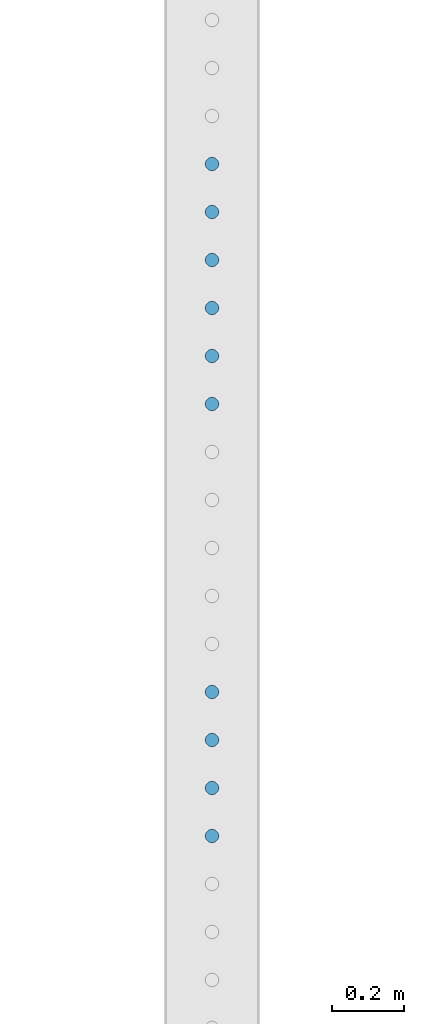
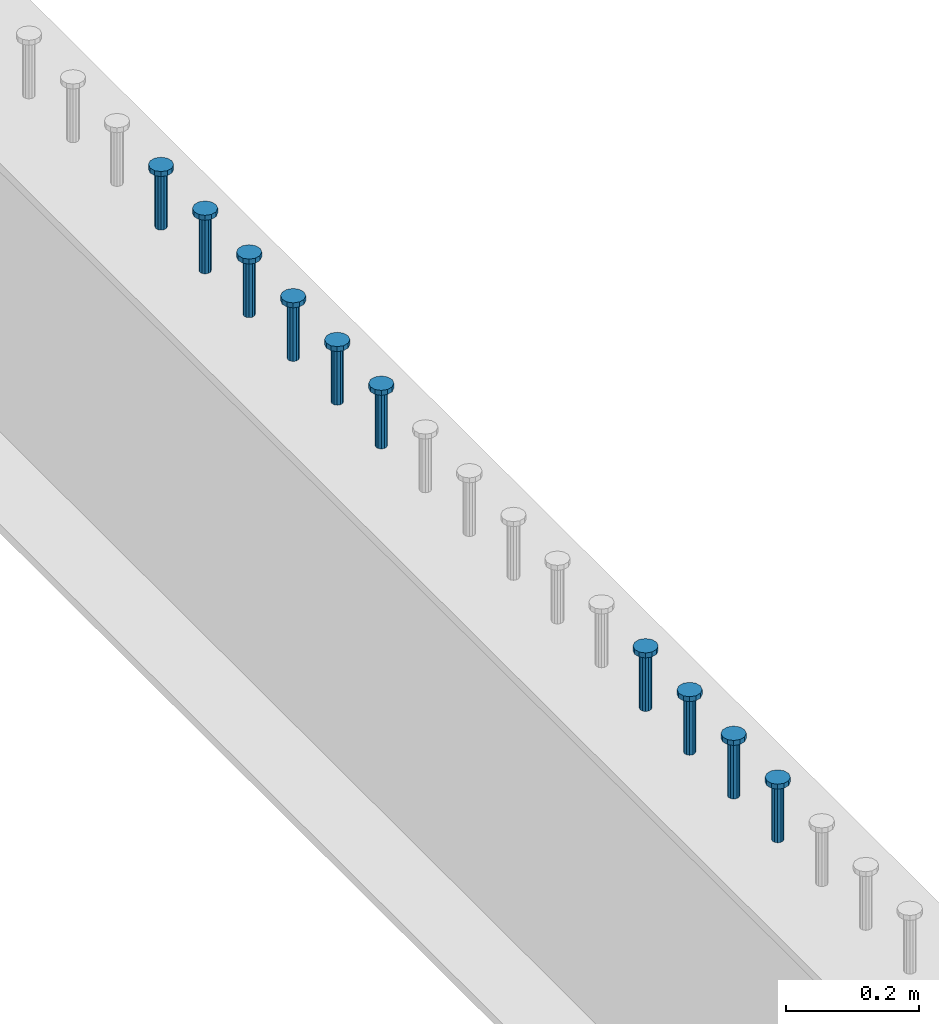
# One storey, part 947 of 1763: 10 columns, 10 elements without a shape of their own.
"""IFC2X3 building model written with IfcOpenShell, lengths in millimetres."""

import ifcopenshell
import ifcopenshell.guid

model = None  # the IFC model being written
_history = None  # IfcOwnerHistory: only IFC2X3 demands one
_inside = {}  # id of a spatial element -> (the spatial element, [elements in it])
_under = {}  # id of a project, library or spatial element -> (it, [spatial elements below it])
_declared = {}  # id of a project -> (the project, [libraries it declares])
_typed = {}  # id of a type object -> (the type object, [elements of that type])
_made_of = {}  # id of a material, layer set ... -> (it, [elements and type objects made of it])


def new_model(schema):
    """Start an empty IFC model of exactly this schema.

    Asked for "IFC4X3", IfcOpenShell would pick the latest addendum, in which some entities
    have other attributes; the version numbers below select the first issue.
    IFC2X3 requires an IfcOwnerHistory on every rooted entity: one is made here for all.
    """
    global model, _history
    if schema == "IFC4X3":
        model = ifcopenshell.file(schema_version=(4, 3, 0, 0))
    else:
        model = ifcopenshell.file(schema=schema)
    _inside.clear()
    _under.clear()
    _declared.clear()
    _typed.clear()
    _made_of.clear()
    _history = None
    if model.schema == "IFC2X3":
        org = make("IfcOrganization", Name="unknown")
        user = make(
            "IfcPersonAndOrganization",
            ThePerson=make("IfcPerson", FamilyName="unknown"),
            TheOrganization=org,
        )
        app = make(
            "IfcApplication",
            ApplicationDeveloper=org,
            Version="unknown",
            ApplicationFullName="unknown",
            ApplicationIdentifier="unknown",
        )
        _history = make(
            "IfcOwnerHistory",
            OwningUser=user,
            OwningApplication=app,
            ChangeAction="ADDED",
            CreationDate=0,
        )
    return model


def make(cls, **values):
    """One entity of the class cls with the attributes given. An attribute that is None is left unset."""
    return model.create_entity(
        cls, **{name: value for name, value in values.items() if value is not None}
    )


def rooted(cls, **values):
    """An entity with a GlobalId (a new one), such as an element, a storey or a relation."""
    return make(cls, GlobalId=ifcopenshell.guid.new(), OwnerHistory=_history, **values)


def si_unit(unit_type, name, prefix=None):
    """IfcSIUnit, for example si_unit("LENGTHUNIT", "METRE", prefix="MILLI")."""
    return make("IfcSIUnit", UnitType=unit_type, Prefix=prefix, Name=name)


def assignment(units):
    """IfcUnitAssignment: the units of a project."""
    return None if units is None else make("IfcUnitAssignment", Units=units)


def point(xyz):
    """IfcCartesianPoint."""
    return None if xyz is None else make("IfcCartesianPoint", Coordinates=xyz)


def direction(xyz):
    """IfcDirection."""
    return None if xyz is None else make("IfcDirection", DirectionRatios=xyz)


def frame(location, z_axis=None, x_axis=None):
    """IfcAxis2Placement3D, a coordinate frame: its origin and axes. An axis left out is left unset."""
    return make(
        "IfcAxis2Placement3D",
        Location=point(location),
        Axis=direction(z_axis),
        RefDirection=direction(x_axis),
    )


def origin_with_axes():
    """The frame at (0, 0, 0) with the z axis (0, 0, 1) and the x axis (1, 0, 0) written out."""
    return frame((0.0, 0.0, 0.0), z_axis=(0.0, 0.0, 1.0), x_axis=(1.0, 0.0, 0.0))


def place(relative_to, where):
    """IfcLocalPlacement: puts the frame where relative to a parent placement (None: the world)."""
    return make(
        "IfcLocalPlacement", PlacementRelTo=relative_to, RelativePlacement=where
    )


def context(
    kind, dimensions, precision=None, world=None, true_north=None, identifier=None
):
    """IfcGeometricRepresentationContext, for example the 3D "Model" context."""
    return make(
        "IfcGeometricRepresentationContext",
        ContextIdentifier=identifier,
        ContextType=kind,
        CoordinateSpaceDimension=dimensions,
        Precision=precision,
        WorldCoordinateSystem=world,
        TrueNorth=true_north,
    )


def subcontext(parent, identifier, kind, view, scale=None):
    """IfcGeometricRepresentationSubContext, for example "Body" below "Model"."""
    return make(
        "IfcGeometricRepresentationSubContext",
        ContextIdentifier=identifier,
        ContextType=kind,
        ParentContext=parent,
        TargetScale=scale,
        TargetView=view,
    )


def project(units=None, contexts=None):
    """IfcProject with its units and contexts."""
    return rooted(
        "IfcProject",
        Name="project",
        RepresentationContexts=contexts,
        UnitsInContext=assignment(units),
    )


def spatial(cls, under=None, at=None, **own):
    """A site, building, storey or space (cls), placed at a placement, below another one or the project."""
    s = rooted(cls, ObjectPlacement=at, **own)
    if under is not None:
        _under.setdefault(under.id(), (under, []))[1].append(s)
    return s


def faces_of(points, faces, orient=None, outer=None):
    """IfcFace entities. A face is a list of loops; a loop is a list of indices into points, from 0.

    orient and outer hold one flag for each loop. By default every Orientation is true, the
    first loop of a face is its IfcFaceOuterBound and the others are IfcFaceBound.
    """
    made = []
    for i, loops in enumerate(faces):
        bounds = []
        for j, loop in enumerate(loops):
            is_outer = j == 0 if outer is None else outer[i][j]
            bounds.append(
                make(
                    "IfcFaceOuterBound" if is_outer else "IfcFaceBound",
                    Bound=make("IfcPolyLoop", Polygon=[points[k] for k in loop]),
                    Orientation=True if orient is None else orient[i][j],
                )
            )
        made.append(make("IfcFace", Bounds=bounds))
    return made


def faceted_brep(points, faces, orient=None, outer=None, voids=None):
    """IfcFacetedBrep: a solid bounded by flat faces; with voids (closed shells), ...WithVoids."""
    shared = [point(p) for p in points]
    hull = make("IfcClosedShell", CfsFaces=faces_of(shared, faces, orient, outer))
    if voids is None:
        return make("IfcFacetedBrep", Outer=hull)
    return make(
        "IfcFacetedBrepWithVoids",
        Outer=hull,
        Voids=[
            make(cls, CfsFaces=faces_of(shared, fs, o, b)) for cls, fs, o, b in voids
        ],
    )


def shape(context_of_items, identifier, shape_type, items):
    """IfcShapeRepresentation: the items that make up one representation, for example the "Body"."""
    return make(
        "IfcShapeRepresentation",
        ContextOfItems=context_of_items,
        RepresentationIdentifier=identifier,
        RepresentationType=shape_type,
        Items=items,
    )


def material(Name=None, Category=None):
    """IfcMaterial."""
    return make("IfcMaterial", Name=Name, Category=Category)


def made_of(thing, what):
    """Note that an element or type object is made of a material, layer set ...; save() writes the relation."""
    if what is not None:
        _made_of.setdefault(what.id(), (what, []))[1].append(thing)
    return thing


def type_object(cls, material=None, **own):
    """A type object (cls), such as IfcWallType, which elements share."""
    return made_of(rooted(cls, **own), material)


def element(
    cls,
    number,
    at=None,
    inside=None,
    cuts=None,
    type_object=None,
    material=None,
    context=None,
    identifier="Body",
    shape_type=None,
    held_by="IfcProductDefinitionShape",
    body=None,
    shapes=None,
    **own,
):
    """One element of the class cls, such as IfcWall. Its Tag is "e" and its number.

    at: its placement. inside: the storey or other place that contains it. cuts: it is an
    opening in that element (IfcRelVoidsElement). A single representation is given by context,
    identifier, shape_type and body (its items); several are given by shapes. held_by: the class
    of the entity that holds the representations. save() writes the other relations.
    """
    e = rooted(cls, Tag="e%d" % number, ObjectPlacement=at, **own)
    if body is not None:
        shapes = [shape(context, identifier, shape_type, body)]
    if shapes is not None:
        e.Representation = make(held_by, Representations=shapes)
    if inside is not None:
        _inside.setdefault(inside.id(), (inside, []))[1].append(e)
    if cuts is not None:
        rooted(
            "IfcRelVoidsElement", RelatingBuildingElement=cuts, RelatedOpeningElement=e
        )
    if type_object is not None:
        _typed.setdefault(type_object.id(), (type_object, []))[1].append(e)
    return made_of(e, material)


def aggregate(whole, parts):
    """IfcRelAggregates: a whole, such as a stair, and the parts it consists of."""
    return rooted("IfcRelAggregates", RelatingObject=whole, RelatedObjects=parts)


def save(model, path):
    """Write the relations noted so far, then the file.

    IfcRelAggregates (storeys below a building ...), IfcRelContainedInSpatialStructure (elements
    in a storey), IfcRelDefinesByType, IfcRelAssociatesMaterial and IfcRelDeclares: one each for
    every whole, place, type object, material and project.
    """
    for whole, parts in _under.values():
        aggregate(whole, parts)
    for where, things in _inside.values():
        rooted(
            "IfcRelContainedInSpatialStructure",
            RelatedElements=things,
            RelatingStructure=where,
        )
    for kind, things in _typed.values():
        rooted("IfcRelDefinesByType", RelatedObjects=things, RelatingType=kind)
    for what, things in _made_of.values():
        rooted("IfcRelAssociatesMaterial", RelatedObjects=things, RelatingMaterial=what)
    for by, libraries in _declared.values():
        rooted("IfcRelDeclares", RelatingContext=by, RelatedDefinitions=libraries)
    model.write(path)


model = new_model("IFC2X3")

# Units and contexts
model_context = context("Model", 3, precision=1e-05, world=origin_with_axes())
body_context = subcontext(model_context, "Body", "Model", "MODEL_VIEW")
ifc_project = project(units=[si_unit("LENGTHUNIT", "METRE", prefix="MILLI"), si_unit("AREAUNIT", "SQUARE_METRE"), si_unit("VOLUMEUNIT", "CUBIC_METRE"), si_unit("MASSUNIT", "GRAM", prefix="KILO"), si_unit("TIMEUNIT", "SECOND"), si_unit("PLANEANGLEUNIT", "RADIAN"), si_unit("SOLIDANGLEUNIT", "STERADIAN"), si_unit("THERMODYNAMICTEMPERATUREUNIT", "DEGREE_CELSIUS"), si_unit("LUMINOUSINTENSITYUNIT", "LUMEN")], contexts=[model_context])

# Site, building, storey
site_placement = place(None, origin_with_axes())
site = spatial("IfcSite", under=ifc_project, at=site_placement, CompositionType="ELEMENT")
building_placement = place(site_placement, origin_with_axes())
building = spatial("IfcBuilding", under=site, at=building_placement, Name="Undefined", CompositionType="ELEMENT")
storey_placement = place(building_placement, origin_with_axes())
storey = spatial("IfcBuildingStorey", under=building, at=storey_placement, Name="Undefined", CompositionType="ELEMENT", Elevation=0.0)

# Assembly, column
assembly_1_placement = place(storey_placement, origin_with_axes())
assembly_1 = element("IfcElementAssembly", 1, at=assembly_1_placement, inside=storey, Name="STUD", AssemblyPlace="NOTDEFINED", PredefinedType="RIGID_FRAME")
ifc_material = material(Name="STEEL/A108")
column_type = type_object("IfcColumnType", Name="STUD_3/4-DIA", PredefinedType="NOTDEFINED")
column_1_placement = place(assembly_1_placement, frame((-24027.8372736984, 40928.3025, 5194.3), z_axis=(-1.0, 0.0, 0.0), x_axis=(0.0, 0.0, 1.0)))
column_1 = element("IfcColumn", 2, at=column_1_placement, type_object=column_type, material=ifc_material, Name="STUD", ObjectType="STUD_3/4-DIA", context=body_context, shape_type="Brep", body=[
    faceted_brep([(0.0, -9.52000045776367, 0.0), (0.0, -8.25, -4.76000022888184), (104.013, -8.25, -4.76000022888184), (104.013, -9.52000045776367, 0.0), (0.0, -4.76000022888184, -8.25), (104.013, -4.76000022888184, -8.25), (0.0, 0.0, -9.52000045776367), (104.013, 0.0, -9.52000045776367), (0.0, 4.76000022888184, -8.25), (104.013, 4.76000022888184, -8.25), (0.0, 8.25, -4.76000022888184), (104.013, 8.25, -4.76000022888184), (0.0, 9.52000045776367, 0.0), (104.013, 9.52000045776367, 0.0), (0.0, 8.25, 4.76000022888184), (104.013, 8.25, 4.76000022888184), (0.0, 4.76000022888184, 8.25), (104.013, 4.76000022888184, 8.25), (0.0, 0.0, 9.52000045776367), (104.013, 0.0, 9.52000045776367), (0.0, -4.76000022888184, 8.25), (104.013, -4.76000022888184, 8.25), (0.0, -8.25, 4.76000022888184), (104.013, -8.25, 4.76000022888184), (105.156, -16.5, -9.52000045776367), (105.156, -19.0499992370605, 0.0), (105.156, -9.52000045776367, -16.5), (105.156, 0.0, -19.0499992370605), (105.156, 9.52000045776367, -16.5), (105.156, 16.5, -9.52000045776367), (105.156, 19.0499992370605, 0.0), (105.156, 16.5, 9.52000045776367), (105.156, 9.52000045776367, 16.5), (105.156, 0.0, 19.0499992370605), (105.156, -9.52000045776367, 16.5), (105.156, -16.5, 9.52000045776367), (114.3, -16.5, -9.52000045776367), (114.299998441489, -19.0500000000029, 0.0), (114.3, -9.52000045776367, -16.5), (114.3, 0.0, -19.0499992370605), (114.3, 9.52000045776367, -16.5), (114.3, 16.5, -9.52000045776367), (114.299998441489, 19.0500000000029, 0.0), (114.3, 16.5, 9.52000045776367), (114.3, 9.52000045776367, 16.5), (114.3, 0.0, 19.0499992370605), (114.3, -9.52000045776367, 16.5), (114.3, -16.5, 9.52000045776367)], [[[0, 1, 2, 3]], [[1, 4, 5, 2]], [[4, 6, 7, 5]], [[6, 8, 9, 7]], [[8, 10, 11, 9]], [[10, 12, 13, 11]], [[12, 14, 15, 13]], [[14, 16, 17, 15]], [[16, 18, 19, 17]], [[18, 20, 21, 19]], [[20, 22, 23, 21]], [[22, 0, 3, 23]], [[22, 20, 18, 16, 14, 12, 10, 8, 6, 4, 1, 0]], [[3, 2, 24, 25]], [[2, 5, 26, 24]], [[5, 7, 27, 26]], [[7, 9, 28, 27]], [[9, 11, 29, 28]], [[11, 13, 30, 29]], [[13, 15, 31, 30]], [[15, 17, 32, 31]], [[17, 19, 33, 32]], [[19, 21, 34, 33]], [[21, 23, 35, 34]], [[23, 3, 25, 35]], [[25, 24, 36, 37]], [[24, 26, 38, 36]], [[26, 27, 39, 38]], [[27, 28, 40, 39]], [[28, 29, 41, 40]], [[29, 30, 42, 41]], [[30, 31, 43, 42]], [[31, 32, 44, 43]], [[32, 33, 45, 44]], [[33, 34, 46, 45]], [[34, 35, 47, 46]], [[35, 25, 37, 47]], [[38, 39, 40, 41, 42, 43, 44, 45, 46, 47, 37, 36]]]),
])
aggregate(assembly_1, [column_1])

assembly_2_placement = place(storey_placement, origin_with_axes())
assembly_2 = element("IfcElementAssembly", 3, at=assembly_2_placement, inside=storey, Name="STUD", AssemblyPlace="NOTDEFINED", PredefinedType="RIGID_FRAME")
column_2_placement = place(assembly_2_placement, frame((-24027.8372736984, 40795.6945, 5194.3), z_axis=(-1.0, 0.0, 0.0), x_axis=(0.0, 0.0, 1.0)))
column_2 = element("IfcColumn", 4, at=column_2_placement, type_object=column_type, material=ifc_material, Name="STUD", ObjectType="STUD_3/4-DIA", context=body_context, shape_type="Brep", body=[
    faceted_brep([(0.0, -9.52000045776367, 0.0), (0.0, -8.25, -4.76000022888184), (104.013, -8.25, -4.76000022888184), (104.013, -9.52000045776367, 0.0), (0.0, -4.76000022888184, -8.25), (104.013, -4.76000022888184, -8.25), (0.0, 0.0, -9.52000045776367), (104.013, 0.0, -9.52000045776367), (0.0, 4.76000022888184, -8.25), (104.013, 4.76000022888184, -8.25), (0.0, 8.25, -4.76000022888184), (104.013, 8.25, -4.76000022888184), (0.0, 9.52000045776367, 0.0), (104.013, 9.52000045776367, 0.0), (0.0, 8.25, 4.76000022888184), (104.013, 8.25, 4.76000022888184), (0.0, 4.76000022888184, 8.25), (104.013, 4.76000022888184, 8.25), (0.0, 0.0, 9.52000045776367), (104.013, 0.0, 9.52000045776367), (0.0, -4.76000022888184, 8.25), (104.013, -4.76000022888184, 8.25), (0.0, -8.25, 4.76000022888184), (104.013, -8.25, 4.76000022888184), (105.156, -16.5, -9.52000045776367), (105.156, -19.0499992370605, 0.0), (105.156, -9.52000045776367, -16.5), (105.156, 0.0, -19.0499992370605), (105.156, 9.52000045776367, -16.5), (105.156, 16.5, -9.52000045776367), (105.156, 19.0499992370605, 0.0), (105.156, 16.5, 9.52000045776367), (105.156, 9.52000045776367, 16.5), (105.156, 0.0, 19.0499992370605), (105.156, -9.52000045776367, 16.5), (105.156, -16.5, 9.52000045776367), (114.3, -16.5, -9.52000045776367), (114.299998441489, -19.0500000000029, 0.0), (114.3, -9.52000045776367, -16.5), (114.3, 0.0, -19.0499992370605), (114.3, 9.52000045776367, -16.5), (114.3, 16.5, -9.52000045776367), (114.299998441489, 19.0500000000029, 0.0), (114.3, 16.5, 9.52000045776367), (114.3, 9.52000045776367, 16.5), (114.3, 0.0, 19.0499992370605), (114.3, -9.52000045776367, 16.5), (114.3, -16.5, 9.52000045776367)], [[[0, 1, 2, 3]], [[1, 4, 5, 2]], [[4, 6, 7, 5]], [[6, 8, 9, 7]], [[8, 10, 11, 9]], [[10, 12, 13, 11]], [[12, 14, 15, 13]], [[14, 16, 17, 15]], [[16, 18, 19, 17]], [[18, 20, 21, 19]], [[20, 22, 23, 21]], [[22, 0, 3, 23]], [[22, 20, 18, 16, 14, 12, 10, 8, 6, 4, 1, 0]], [[3, 2, 24, 25]], [[2, 5, 26, 24]], [[5, 7, 27, 26]], [[7, 9, 28, 27]], [[9, 11, 29, 28]], [[11, 13, 30, 29]], [[13, 15, 31, 30]], [[15, 17, 32, 31]], [[17, 19, 33, 32]], [[19, 21, 34, 33]], [[21, 23, 35, 34]], [[23, 3, 25, 35]], [[25, 24, 36, 37]], [[24, 26, 38, 36]], [[26, 27, 39, 38]], [[27, 28, 40, 39]], [[28, 29, 41, 40]], [[29, 30, 42, 41]], [[30, 31, 43, 42]], [[31, 32, 44, 43]], [[32, 33, 45, 44]], [[33, 34, 46, 45]], [[34, 35, 47, 46]], [[35, 25, 37, 47]], [[38, 39, 40, 41, 42, 43, 44, 45, 46, 47, 37, 36]]]),
])
aggregate(assembly_2, [column_2])

assembly_3_placement = place(storey_placement, origin_with_axes())
assembly_3 = element("IfcElementAssembly", 5, at=assembly_3_placement, inside=storey, Name="STUD", AssemblyPlace="NOTDEFINED", PredefinedType="RIGID_FRAME")
column_3_placement = place(assembly_3_placement, frame((-24027.8372736984, 40663.0865, 5194.3), z_axis=(-1.0, 0.0, 0.0), x_axis=(0.0, 0.0, 1.0)))
column_3 = element("IfcColumn", 6, at=column_3_placement, type_object=column_type, material=ifc_material, Name="STUD", ObjectType="STUD_3/4-DIA", context=body_context, shape_type="Brep", body=[
    faceted_brep([(0.0, -9.52000045776367, 0.0), (0.0, -8.25, -4.76000022888184), (104.013, -8.25, -4.76000022888184), (104.013, -9.52000045776367, 0.0), (0.0, -4.76000022888184, -8.25), (104.013, -4.76000022888184, -8.25), (0.0, 0.0, -9.52000045776367), (104.013, 0.0, -9.52000045776367), (0.0, 4.76000022888184, -8.25), (104.013, 4.76000022888184, -8.25), (0.0, 8.25, -4.76000022888184), (104.013, 8.25, -4.76000022888184), (0.0, 9.52000045776367, 0.0), (104.013, 9.52000045776367, 0.0), (0.0, 8.25, 4.76000022888184), (104.013, 8.25, 4.76000022888184), (0.0, 4.76000022888184, 8.25), (104.013, 4.76000022888184, 8.25), (0.0, 0.0, 9.52000045776367), (104.013, 0.0, 9.52000045776367), (0.0, -4.76000022888184, 8.25), (104.013, -4.76000022888184, 8.25), (0.0, -8.25, 4.76000022888184), (104.013, -8.25, 4.76000022888184), (105.156, -16.5, -9.52000045776367), (105.156, -19.0499992370605, 0.0), (105.156, -9.52000045776367, -16.5), (105.156, 0.0, -19.0499992370605), (105.156, 9.52000045776367, -16.5), (105.156, 16.5, -9.52000045776367), (105.156, 19.0499992370605, 0.0), (105.156, 16.5, 9.52000045776367), (105.156, 9.52000045776367, 16.5), (105.156, 0.0, 19.0499992370605), (105.156, -9.52000045776367, 16.5), (105.156, -16.5, 9.52000045776367), (114.3, -16.5, -9.52000045776367), (114.299998441489, -19.0500000000029, 0.0), (114.3, -9.52000045776367, -16.5), (114.3, 0.0, -19.0499992370605), (114.3, 9.52000045776367, -16.5), (114.3, 16.5, -9.52000045776367), (114.299998441489, 19.0500000000029, 0.0), (114.3, 16.5, 9.52000045776367), (114.3, 9.52000045776367, 16.5), (114.3, 0.0, 19.0499992370605), (114.3, -9.52000045776367, 16.5), (114.3, -16.5, 9.52000045776367)], [[[0, 1, 2, 3]], [[1, 4, 5, 2]], [[4, 6, 7, 5]], [[6, 8, 9, 7]], [[8, 10, 11, 9]], [[10, 12, 13, 11]], [[12, 14, 15, 13]], [[14, 16, 17, 15]], [[16, 18, 19, 17]], [[18, 20, 21, 19]], [[20, 22, 23, 21]], [[22, 0, 3, 23]], [[22, 20, 18, 16, 14, 12, 10, 8, 6, 4, 1, 0]], [[3, 2, 24, 25]], [[2, 5, 26, 24]], [[5, 7, 27, 26]], [[7, 9, 28, 27]], [[9, 11, 29, 28]], [[11, 13, 30, 29]], [[13, 15, 31, 30]], [[15, 17, 32, 31]], [[17, 19, 33, 32]], [[19, 21, 34, 33]], [[21, 23, 35, 34]], [[23, 3, 25, 35]], [[25, 24, 36, 37]], [[24, 26, 38, 36]], [[26, 27, 39, 38]], [[27, 28, 40, 39]], [[28, 29, 41, 40]], [[29, 30, 42, 41]], [[30, 31, 43, 42]], [[31, 32, 44, 43]], [[32, 33, 45, 44]], [[33, 34, 46, 45]], [[34, 35, 47, 46]], [[35, 25, 37, 47]], [[38, 39, 40, 41, 42, 43, 44, 45, 46, 47, 37, 36]]]),
])
aggregate(assembly_3, [column_3])

assembly_4_placement = place(storey_placement, origin_with_axes())
assembly_4 = element("IfcElementAssembly", 7, at=assembly_4_placement, inside=storey, Name="STUD", AssemblyPlace="NOTDEFINED", PredefinedType="RIGID_FRAME")
column_4_placement = place(assembly_4_placement, frame((-24027.8372736984, 40530.4785, 5194.3), z_axis=(-1.0, 0.0, 0.0), x_axis=(0.0, 0.0, 1.0)))
column_4 = element("IfcColumn", 8, at=column_4_placement, type_object=column_type, material=ifc_material, Name="STUD", ObjectType="STUD_3/4-DIA", context=body_context, shape_type="Brep", body=[
    faceted_brep([(0.0, -9.52000045776367, 0.0), (0.0, -8.25, -4.76000022888184), (104.013, -8.25, -4.76000022888184), (104.013, -9.52000045776367, 0.0), (0.0, -4.76000022888184, -8.25), (104.013, -4.76000022888184, -8.25), (0.0, 0.0, -9.52000045776367), (104.013, 0.0, -9.52000045776367), (0.0, 4.76000022888184, -8.25), (104.013, 4.76000022888184, -8.25), (0.0, 8.25, -4.76000022888184), (104.013, 8.25, -4.76000022888184), (0.0, 9.52000045776367, 0.0), (104.013, 9.52000045776367, 0.0), (0.0, 8.25, 4.76000022888184), (104.013, 8.25, 4.76000022888184), (0.0, 4.76000022888184, 8.25), (104.013, 4.76000022888184, 8.25), (0.0, 0.0, 9.52000045776367), (104.013, 0.0, 9.52000045776367), (0.0, -4.76000022888184, 8.25), (104.013, -4.76000022888184, 8.25), (0.0, -8.25, 4.76000022888184), (104.013, -8.25, 4.76000022888184), (105.156, -16.5, -9.52000045776367), (105.156, -19.0499992370605, 0.0), (105.156, -9.52000045776367, -16.5), (105.156, 0.0, -19.0499992370605), (105.156, 9.52000045776367, -16.5), (105.156, 16.5, -9.52000045776367), (105.156, 19.0499992370605, 0.0), (105.156, 16.5, 9.52000045776367), (105.156, 9.52000045776367, 16.5), (105.156, 0.0, 19.0499992370605), (105.156, -9.52000045776367, 16.5), (105.156, -16.5, 9.52000045776367), (114.3, -16.5, -9.52000045776367), (114.299998441489, -19.0500000000029, 0.0), (114.3, -9.52000045776367, -16.5), (114.3, 0.0, -19.0499992370605), (114.3, 9.52000045776367, -16.5), (114.3, 16.5, -9.52000045776367), (114.299998441489, 19.0500000000029, 0.0), (114.3, 16.5, 9.52000045776367), (114.3, 9.52000045776367, 16.5), (114.3, 0.0, 19.0499992370605), (114.3, -9.52000045776367, 16.5), (114.3, -16.5, 9.52000045776367)], [[[0, 1, 2, 3]], [[1, 4, 5, 2]], [[4, 6, 7, 5]], [[6, 8, 9, 7]], [[8, 10, 11, 9]], [[10, 12, 13, 11]], [[12, 14, 15, 13]], [[14, 16, 17, 15]], [[16, 18, 19, 17]], [[18, 20, 21, 19]], [[20, 22, 23, 21]], [[22, 0, 3, 23]], [[22, 20, 18, 16, 14, 12, 10, 8, 6, 4, 1, 0]], [[3, 2, 24, 25]], [[2, 5, 26, 24]], [[5, 7, 27, 26]], [[7, 9, 28, 27]], [[9, 11, 29, 28]], [[11, 13, 30, 29]], [[13, 15, 31, 30]], [[15, 17, 32, 31]], [[17, 19, 33, 32]], [[19, 21, 34, 33]], [[21, 23, 35, 34]], [[23, 3, 25, 35]], [[25, 24, 36, 37]], [[24, 26, 38, 36]], [[26, 27, 39, 38]], [[27, 28, 40, 39]], [[28, 29, 41, 40]], [[29, 30, 42, 41]], [[30, 31, 43, 42]], [[31, 32, 44, 43]], [[32, 33, 45, 44]], [[33, 34, 46, 45]], [[34, 35, 47, 46]], [[35, 25, 37, 47]], [[38, 39, 40, 41, 42, 43, 44, 45, 46, 47, 37, 36]]]),
])
aggregate(assembly_4, [column_4])

assembly_5_placement = place(storey_placement, origin_with_axes())
assembly_5 = element("IfcElementAssembly", 9, at=assembly_5_placement, inside=storey, Name="STUD", AssemblyPlace="NOTDEFINED", PredefinedType="RIGID_FRAME")
column_5_placement = place(assembly_5_placement, frame((-24027.8372736984, 40397.8705, 5194.3), z_axis=(-1.0, 0.0, 0.0), x_axis=(0.0, 0.0, 1.0)))
column_5 = element("IfcColumn", 10, at=column_5_placement, type_object=column_type, material=ifc_material, Name="STUD", ObjectType="STUD_3/4-DIA", context=body_context, shape_type="Brep", body=[
    faceted_brep([(0.0, -9.52000045776367, 0.0), (0.0, -8.25, -4.76000022888184), (104.013, -8.25, -4.76000022888184), (104.013, -9.52000045776367, 0.0), (0.0, -4.76000022888184, -8.25), (104.013, -4.76000022888184, -8.25), (0.0, 0.0, -9.52000045776367), (104.013, 0.0, -9.52000045776367), (0.0, 4.76000022888184, -8.25), (104.013, 4.76000022888184, -8.25), (0.0, 8.25, -4.76000022888184), (104.013, 8.25, -4.76000022888184), (0.0, 9.52000045776367, 0.0), (104.013, 9.52000045776367, 0.0), (0.0, 8.25, 4.76000022888184), (104.013, 8.25, 4.76000022888184), (0.0, 4.76000022888184, 8.25), (104.013, 4.76000022888184, 8.25), (0.0, 0.0, 9.52000045776367), (104.013, 0.0, 9.52000045776367), (0.0, -4.76000022888184, 8.25), (104.013, -4.76000022888184, 8.25), (0.0, -8.25, 4.76000022888184), (104.013, -8.25, 4.76000022888184), (105.156, -16.5, -9.52000045776367), (105.156, -19.0499992370605, 0.0), (105.156, -9.52000045776367, -16.5), (105.156, 0.0, -19.0499992370605), (105.156, 9.52000045776367, -16.5), (105.156, 16.5, -9.52000045776367), (105.156, 19.0499992370605, 0.0), (105.156, 16.5, 9.52000045776367), (105.156, 9.52000045776367, 16.5), (105.156, 0.0, 19.0499992370605), (105.156, -9.52000045776367, 16.5), (105.156, -16.5, 9.52000045776367), (114.3, -16.5, -9.52000045776367), (114.299998441489, -19.0500000000029, 0.0), (114.3, -9.52000045776367, -16.5), (114.3, 0.0, -19.0499992370605), (114.3, 9.52000045776367, -16.5), (114.3, 16.5, -9.52000045776367), (114.299998441489, 19.0500000000029, 0.0), (114.3, 16.5, 9.52000045776367), (114.3, 9.52000045776367, 16.5), (114.3, 0.0, 19.0499992370605), (114.3, -9.52000045776367, 16.5), (114.3, -16.5, 9.52000045776367)], [[[0, 1, 2, 3]], [[1, 4, 5, 2]], [[4, 6, 7, 5]], [[6, 8, 9, 7]], [[8, 10, 11, 9]], [[10, 12, 13, 11]], [[12, 14, 15, 13]], [[14, 16, 17, 15]], [[16, 18, 19, 17]], [[18, 20, 21, 19]], [[20, 22, 23, 21]], [[22, 0, 3, 23]], [[22, 20, 18, 16, 14, 12, 10, 8, 6, 4, 1, 0]], [[3, 2, 24, 25]], [[2, 5, 26, 24]], [[5, 7, 27, 26]], [[7, 9, 28, 27]], [[9, 11, 29, 28]], [[11, 13, 30, 29]], [[13, 15, 31, 30]], [[15, 17, 32, 31]], [[17, 19, 33, 32]], [[19, 21, 34, 33]], [[21, 23, 35, 34]], [[23, 3, 25, 35]], [[25, 24, 36, 37]], [[24, 26, 38, 36]], [[26, 27, 39, 38]], [[27, 28, 40, 39]], [[28, 29, 41, 40]], [[29, 30, 42, 41]], [[30, 31, 43, 42]], [[31, 32, 44, 43]], [[32, 33, 45, 44]], [[33, 34, 46, 45]], [[34, 35, 47, 46]], [[35, 25, 37, 47]], [[38, 39, 40, 41, 42, 43, 44, 45, 46, 47, 37, 36]]]),
])
aggregate(assembly_5, [column_5])

assembly_6_placement = place(storey_placement, origin_with_axes())
assembly_6 = element("IfcElementAssembly", 11, at=assembly_6_placement, inside=storey, Name="STUD", AssemblyPlace="NOTDEFINED", PredefinedType="RIGID_FRAME")
column_6_placement = place(assembly_6_placement, frame((-24027.8372736984, 40265.2625, 5194.3), z_axis=(-1.0, 0.0, 0.0), x_axis=(0.0, 0.0, 1.0)))
column_6 = element("IfcColumn", 12, at=column_6_placement, type_object=column_type, material=ifc_material, Name="STUD", ObjectType="STUD_3/4-DIA", context=body_context, shape_type="Brep", body=[
    faceted_brep([(0.0, -9.52000045776367, 0.0), (0.0, -8.25, -4.76000022888184), (104.013, -8.25, -4.76000022888184), (104.013, -9.52000045776367, 0.0), (0.0, -4.76000022888184, -8.25), (104.013, -4.76000022888184, -8.25), (0.0, 0.0, -9.52000045776367), (104.013, 0.0, -9.52000045776367), (0.0, 4.76000022888184, -8.25), (104.013, 4.76000022888184, -8.25), (0.0, 8.25, -4.76000022888184), (104.013, 8.25, -4.76000022888184), (0.0, 9.52000045776367, 0.0), (104.013, 9.52000045776367, 0.0), (0.0, 8.25, 4.76000022888184), (104.013, 8.25, 4.76000022888184), (0.0, 4.76000022888184, 8.25), (104.013, 4.76000022888184, 8.25), (0.0, 0.0, 9.52000045776367), (104.013, 0.0, 9.52000045776367), (0.0, -4.76000022888184, 8.25), (104.013, -4.76000022888184, 8.25), (0.0, -8.25, 4.76000022888184), (104.013, -8.25, 4.76000022888184), (105.156, -16.5, -9.52000045776367), (105.156, -19.0499992370605, 0.0), (105.156, -9.52000045776367, -16.5), (105.156, 0.0, -19.0499992370605), (105.156, 9.52000045776367, -16.5), (105.156, 16.5, -9.52000045776367), (105.156, 19.0499992370605, 0.0), (105.156, 16.5, 9.52000045776367), (105.156, 9.52000045776367, 16.5), (105.156, 0.0, 19.0499992370605), (105.156, -9.52000045776367, 16.5), (105.156, -16.5, 9.52000045776367), (114.3, -16.5, -9.52000045776367), (114.299998441489, -19.0500000000029, 0.0), (114.3, -9.52000045776367, -16.5), (114.3, 0.0, -19.0499992370605), (114.3, 9.52000045776367, -16.5), (114.3, 16.5, -9.52000045776367), (114.299998441489, 19.0500000000029, 0.0), (114.3, 16.5, 9.52000045776367), (114.3, 9.52000045776367, 16.5), (114.3, 0.0, 19.0499992370605), (114.3, -9.52000045776367, 16.5), (114.3, -16.5, 9.52000045776367)], [[[0, 1, 2, 3]], [[1, 4, 5, 2]], [[4, 6, 7, 5]], [[6, 8, 9, 7]], [[8, 10, 11, 9]], [[10, 12, 13, 11]], [[12, 14, 15, 13]], [[14, 16, 17, 15]], [[16, 18, 19, 17]], [[18, 20, 21, 19]], [[20, 22, 23, 21]], [[22, 0, 3, 23]], [[22, 20, 18, 16, 14, 12, 10, 8, 6, 4, 1, 0]], [[3, 2, 24, 25]], [[2, 5, 26, 24]], [[5, 7, 27, 26]], [[7, 9, 28, 27]], [[9, 11, 29, 28]], [[11, 13, 30, 29]], [[13, 15, 31, 30]], [[15, 17, 32, 31]], [[17, 19, 33, 32]], [[19, 21, 34, 33]], [[21, 23, 35, 34]], [[23, 3, 25, 35]], [[25, 24, 36, 37]], [[24, 26, 38, 36]], [[26, 27, 39, 38]], [[27, 28, 40, 39]], [[28, 29, 41, 40]], [[29, 30, 42, 41]], [[30, 31, 43, 42]], [[31, 32, 44, 43]], [[32, 33, 45, 44]], [[33, 34, 46, 45]], [[34, 35, 47, 46]], [[35, 25, 37, 47]], [[38, 39, 40, 41, 42, 43, 44, 45, 46, 47, 37, 36]]]),
])
aggregate(assembly_6, [column_6])

assembly_7_placement = place(storey_placement, origin_with_axes())
assembly_7 = element("IfcElementAssembly", 13, at=assembly_7_placement, inside=storey, Name="STUD", AssemblyPlace="NOTDEFINED", PredefinedType="RIGID_FRAME")
column_7_placement = place(assembly_7_placement, frame((-24027.8372736984, 39469.6145, 5194.3), z_axis=(-1.0, 0.0, 0.0), x_axis=(0.0, 0.0, 1.0)))
column_7 = element("IfcColumn", 14, at=column_7_placement, type_object=column_type, material=ifc_material, Name="STUD", ObjectType="STUD_3/4-DIA", context=body_context, shape_type="Brep", body=[
    faceted_brep([(0.0, -9.52000045776367, 0.0), (0.0, -8.25, -4.76000022888184), (104.013, -8.25, -4.76000022888184), (104.013, -9.52000045776367, 0.0), (0.0, -4.76000022888184, -8.25), (104.013, -4.76000022888184, -8.25), (0.0, 0.0, -9.52000045776367), (104.013, 0.0, -9.52000045776367), (0.0, 4.76000022888184, -8.25), (104.013, 4.76000022888184, -8.25), (0.0, 8.25, -4.76000022888184), (104.013, 8.25, -4.76000022888184), (0.0, 9.52000045776367, 0.0), (104.013, 9.52000045776367, 0.0), (0.0, 8.25, 4.76000022888184), (104.013, 8.25, 4.76000022888184), (0.0, 4.76000022888184, 8.25), (104.013, 4.76000022888184, 8.25), (0.0, 0.0, 9.52000045776367), (104.013, 0.0, 9.52000045776367), (0.0, -4.76000022888184, 8.25), (104.013, -4.76000022888184, 8.25), (0.0, -8.25, 4.76000022888184), (104.013, -8.25, 4.76000022888184), (105.156, -16.5, -9.52000045776367), (105.156, -19.0499992370605, 0.0), (105.156, -9.52000045776367, -16.5), (105.156, 0.0, -19.0499992370605), (105.156, 9.52000045776367, -16.5), (105.156, 16.5, -9.52000045776367), (105.156, 19.0499992370605, 0.0), (105.156, 16.5, 9.52000045776367), (105.156, 9.52000045776367, 16.5), (105.156, 0.0, 19.0499992370605), (105.156, -9.52000045776367, 16.5), (105.156, -16.5, 9.52000045776367), (114.3, -16.5, -9.52000045776367), (114.299998441489, -19.0500000000029, 0.0), (114.3, -9.52000045776367, -16.5), (114.3, 0.0, -19.0499992370605), (114.3, 9.52000045776367, -16.5), (114.3, 16.5, -9.52000045776367), (114.299998441489, 19.0500000000029, 0.0), (114.3, 16.5, 9.52000045776367), (114.3, 9.52000045776367, 16.5), (114.3, 0.0, 19.0499992370605), (114.3, -9.52000045776367, 16.5), (114.3, -16.5, 9.52000045776367)], [[[0, 1, 2, 3]], [[1, 4, 5, 2]], [[4, 6, 7, 5]], [[6, 8, 9, 7]], [[8, 10, 11, 9]], [[10, 12, 13, 11]], [[12, 14, 15, 13]], [[14, 16, 17, 15]], [[16, 18, 19, 17]], [[18, 20, 21, 19]], [[20, 22, 23, 21]], [[22, 0, 3, 23]], [[22, 20, 18, 16, 14, 12, 10, 8, 6, 4, 1, 0]], [[3, 2, 24, 25]], [[2, 5, 26, 24]], [[5, 7, 27, 26]], [[7, 9, 28, 27]], [[9, 11, 29, 28]], [[11, 13, 30, 29]], [[13, 15, 31, 30]], [[15, 17, 32, 31]], [[17, 19, 33, 32]], [[19, 21, 34, 33]], [[21, 23, 35, 34]], [[23, 3, 25, 35]], [[25, 24, 36, 37]], [[24, 26, 38, 36]], [[26, 27, 39, 38]], [[27, 28, 40, 39]], [[28, 29, 41, 40]], [[29, 30, 42, 41]], [[30, 31, 43, 42]], [[31, 32, 44, 43]], [[32, 33, 45, 44]], [[33, 34, 46, 45]], [[34, 35, 47, 46]], [[35, 25, 37, 47]], [[38, 39, 40, 41, 42, 43, 44, 45, 46, 47, 37, 36]]]),
])
aggregate(assembly_7, [column_7])

assembly_8_placement = place(storey_placement, origin_with_axes())
assembly_8 = element("IfcElementAssembly", 15, at=assembly_8_placement, inside=storey, Name="STUD", AssemblyPlace="NOTDEFINED", PredefinedType="RIGID_FRAME")
column_8_placement = place(assembly_8_placement, frame((-24027.8372736984, 39337.0065, 5194.3), z_axis=(-1.0, 0.0, 0.0), x_axis=(0.0, 0.0, 1.0)))
column_8 = element("IfcColumn", 16, at=column_8_placement, type_object=column_type, material=ifc_material, Name="STUD", ObjectType="STUD_3/4-DIA", context=body_context, shape_type="Brep", body=[
    faceted_brep([(0.0, -9.52000045776367, 0.0), (0.0, -8.25, -4.76000022888184), (104.013, -8.25, -4.76000022888184), (104.013, -9.52000045776367, 0.0), (0.0, -4.76000022888184, -8.25), (104.013, -4.76000022888184, -8.25), (0.0, 0.0, -9.52000045776367), (104.013, 0.0, -9.52000045776367), (0.0, 4.76000022888184, -8.25), (104.013, 4.76000022888184, -8.25), (0.0, 8.25, -4.76000022888184), (104.013, 8.25, -4.76000022888184), (0.0, 9.52000045776367, 0.0), (104.013, 9.52000045776367, 0.0), (0.0, 8.25, 4.76000022888184), (104.013, 8.25, 4.76000022888184), (0.0, 4.76000022888184, 8.25), (104.013, 4.76000022888184, 8.25), (0.0, 0.0, 9.52000045776367), (104.013, 0.0, 9.52000045776367), (0.0, -4.76000022888184, 8.25), (104.013, -4.76000022888184, 8.25), (0.0, -8.25, 4.76000022888184), (104.013, -8.25, 4.76000022888184), (105.156, -16.5, -9.52000045776367), (105.156, -19.0499992370605, 0.0), (105.156, -9.52000045776367, -16.5), (105.156, 0.0, -19.0499992370605), (105.156, 9.52000045776367, -16.5), (105.156, 16.5, -9.52000045776367), (105.156, 19.0499992370605, 0.0), (105.156, 16.5, 9.52000045776367), (105.156, 9.52000045776367, 16.5), (105.156, 0.0, 19.0499992370605), (105.156, -9.52000045776367, 16.5), (105.156, -16.5, 9.52000045776367), (114.3, -16.5, -9.52000045776367), (114.299998441489, -19.0500000000029, 0.0), (114.3, -9.52000045776367, -16.5), (114.3, 0.0, -19.0499992370605), (114.3, 9.52000045776367, -16.5), (114.3, 16.5, -9.52000045776367), (114.299998441489, 19.0500000000029, 0.0), (114.3, 16.5, 9.52000045776367), (114.3, 9.52000045776367, 16.5), (114.3, 0.0, 19.0499992370605), (114.3, -9.52000045776367, 16.5), (114.3, -16.5, 9.52000045776367)], [[[0, 1, 2, 3]], [[1, 4, 5, 2]], [[4, 6, 7, 5]], [[6, 8, 9, 7]], [[8, 10, 11, 9]], [[10, 12, 13, 11]], [[12, 14, 15, 13]], [[14, 16, 17, 15]], [[16, 18, 19, 17]], [[18, 20, 21, 19]], [[20, 22, 23, 21]], [[22, 0, 3, 23]], [[22, 20, 18, 16, 14, 12, 10, 8, 6, 4, 1, 0]], [[3, 2, 24, 25]], [[2, 5, 26, 24]], [[5, 7, 27, 26]], [[7, 9, 28, 27]], [[9, 11, 29, 28]], [[11, 13, 30, 29]], [[13, 15, 31, 30]], [[15, 17, 32, 31]], [[17, 19, 33, 32]], [[19, 21, 34, 33]], [[21, 23, 35, 34]], [[23, 3, 25, 35]], [[25, 24, 36, 37]], [[24, 26, 38, 36]], [[26, 27, 39, 38]], [[27, 28, 40, 39]], [[28, 29, 41, 40]], [[29, 30, 42, 41]], [[30, 31, 43, 42]], [[31, 32, 44, 43]], [[32, 33, 45, 44]], [[33, 34, 46, 45]], [[34, 35, 47, 46]], [[35, 25, 37, 47]], [[38, 39, 40, 41, 42, 43, 44, 45, 46, 47, 37, 36]]]),
])
aggregate(assembly_8, [column_8])

assembly_9_placement = place(storey_placement, origin_with_axes())
assembly_9 = element("IfcElementAssembly", 17, at=assembly_9_placement, inside=storey, Name="STUD", AssemblyPlace="NOTDEFINED", PredefinedType="RIGID_FRAME")
column_9_placement = place(assembly_9_placement, frame((-24027.8372736984, 39204.3985, 5194.3), z_axis=(-1.0, 0.0, 0.0), x_axis=(0.0, 0.0, 1.0)))
column_9 = element("IfcColumn", 18, at=column_9_placement, type_object=column_type, material=ifc_material, Name="STUD", ObjectType="STUD_3/4-DIA", context=body_context, shape_type="Brep", body=[
    faceted_brep([(0.0, -9.52000045776367, 0.0), (0.0, -8.25, -4.76000022888184), (104.013, -8.25, -4.76000022888184), (104.013, -9.52000045776367, 0.0), (0.0, -4.76000022888184, -8.25), (104.013, -4.76000022888184, -8.25), (0.0, 0.0, -9.52000045776367), (104.013, 0.0, -9.52000045776367), (0.0, 4.76000022888184, -8.25), (104.013, 4.76000022888184, -8.25), (0.0, 8.25, -4.76000022888184), (104.013, 8.25, -4.76000022888184), (0.0, 9.52000045776367, 0.0), (104.013, 9.52000045776367, 0.0), (0.0, 8.25, 4.76000022888184), (104.013, 8.25, 4.76000022888184), (0.0, 4.76000022888184, 8.25), (104.013, 4.76000022888184, 8.25), (0.0, 0.0, 9.52000045776367), (104.013, 0.0, 9.52000045776367), (0.0, -4.76000022888184, 8.25), (104.013, -4.76000022888184, 8.25), (0.0, -8.25, 4.76000022888184), (104.013, -8.25, 4.76000022888184), (105.156, -16.5, -9.52000045776367), (105.156, -19.0499992370605, 0.0), (105.156, -9.52000045776367, -16.5), (105.156, 0.0, -19.0499992370605), (105.156, 9.52000045776367, -16.5), (105.156, 16.5, -9.52000045776367), (105.156, 19.0499992370605, 0.0), (105.156, 16.5, 9.52000045776367), (105.156, 9.52000045776367, 16.5), (105.156, 0.0, 19.0499992370605), (105.156, -9.52000045776367, 16.5), (105.156, -16.5, 9.52000045776367), (114.3, -16.5, -9.52000045776367), (114.299998441489, -19.0500000000029, 0.0), (114.3, -9.52000045776367, -16.5), (114.3, 0.0, -19.0499992370605), (114.3, 9.52000045776367, -16.5), (114.3, 16.5, -9.52000045776367), (114.299998441489, 19.0500000000029, 0.0), (114.3, 16.5, 9.52000045776367), (114.3, 9.52000045776367, 16.5), (114.3, 0.0, 19.0499992370605), (114.3, -9.52000045776367, 16.5), (114.3, -16.5, 9.52000045776367)], [[[0, 1, 2, 3]], [[1, 4, 5, 2]], [[4, 6, 7, 5]], [[6, 8, 9, 7]], [[8, 10, 11, 9]], [[10, 12, 13, 11]], [[12, 14, 15, 13]], [[14, 16, 17, 15]], [[16, 18, 19, 17]], [[18, 20, 21, 19]], [[20, 22, 23, 21]], [[22, 0, 3, 23]], [[22, 20, 18, 16, 14, 12, 10, 8, 6, 4, 1, 0]], [[3, 2, 24, 25]], [[2, 5, 26, 24]], [[5, 7, 27, 26]], [[7, 9, 28, 27]], [[9, 11, 29, 28]], [[11, 13, 30, 29]], [[13, 15, 31, 30]], [[15, 17, 32, 31]], [[17, 19, 33, 32]], [[19, 21, 34, 33]], [[21, 23, 35, 34]], [[23, 3, 25, 35]], [[25, 24, 36, 37]], [[24, 26, 38, 36]], [[26, 27, 39, 38]], [[27, 28, 40, 39]], [[28, 29, 41, 40]], [[29, 30, 42, 41]], [[30, 31, 43, 42]], [[31, 32, 44, 43]], [[32, 33, 45, 44]], [[33, 34, 46, 45]], [[34, 35, 47, 46]], [[35, 25, 37, 47]], [[38, 39, 40, 41, 42, 43, 44, 45, 46, 47, 37, 36]]]),
])
aggregate(assembly_9, [column_9])

assembly_10_placement = place(storey_placement, origin_with_axes())
assembly_10 = element("IfcElementAssembly", 19, at=assembly_10_placement, inside=storey, Name="STUD", AssemblyPlace="NOTDEFINED", PredefinedType="RIGID_FRAME")
column_10_placement = place(assembly_10_placement, frame((-24027.8372736984, 39071.7905, 5194.3), z_axis=(-1.0, 0.0, 0.0), x_axis=(0.0, 0.0, 1.0)))
column_10 = element("IfcColumn", 20, at=column_10_placement, type_object=column_type, material=ifc_material, Name="STUD", ObjectType="STUD_3/4-DIA", context=body_context, shape_type="Brep", body=[
    faceted_brep([(0.0, -9.52000045776367, 0.0), (0.0, -8.25, -4.76000022888184), (104.013, -8.25, -4.76000022888184), (104.013, -9.52000045776367, 0.0), (0.0, -4.76000022888184, -8.25), (104.013, -4.76000022888184, -8.25), (0.0, 0.0, -9.52000045776367), (104.013, 0.0, -9.52000045776367), (0.0, 4.76000022888184, -8.25), (104.013, 4.76000022888184, -8.25), (0.0, 8.25, -4.76000022888184), (104.013, 8.25, -4.76000022888184), (0.0, 9.52000045776367, 0.0), (104.013, 9.52000045776367, 0.0), (0.0, 8.25, 4.76000022888184), (104.013, 8.25, 4.76000022888184), (0.0, 4.76000022888184, 8.25), (104.013, 4.76000022888184, 8.25), (0.0, 0.0, 9.52000045776367), (104.013, 0.0, 9.52000045776367), (0.0, -4.76000022888184, 8.25), (104.013, -4.76000022888184, 8.25), (0.0, -8.25, 4.76000022888184), (104.013, -8.25, 4.76000022888184), (105.156, -16.5, -9.52000045776367), (105.156, -19.0499992370605, 0.0), (105.156, -9.52000045776367, -16.5), (105.156, 0.0, -19.0499992370605), (105.156, 9.52000045776367, -16.5), (105.156, 16.5, -9.52000045776367), (105.156, 19.0499992370605, 0.0), (105.156, 16.5, 9.52000045776367), (105.156, 9.52000045776367, 16.5), (105.156, 0.0, 19.0499992370605), (105.156, -9.52000045776367, 16.5), (105.156, -16.5, 9.52000045776367), (114.3, -16.5, -9.52000045776367), (114.299998441489, -19.0500000000029, 0.0), (114.3, -9.52000045776367, -16.5), (114.3, 0.0, -19.0499992370605), (114.3, 9.52000045776367, -16.5), (114.3, 16.5, -9.52000045776367), (114.299998441489, 19.0500000000029, 0.0), (114.3, 16.5, 9.52000045776367), (114.3, 9.52000045776367, 16.5), (114.3, 0.0, 19.0499992370605), (114.3, -9.52000045776367, 16.5), (114.3, -16.5, 9.52000045776367)], [[[0, 1, 2, 3]], [[1, 4, 5, 2]], [[4, 6, 7, 5]], [[6, 8, 9, 7]], [[8, 10, 11, 9]], [[10, 12, 13, 11]], [[12, 14, 15, 13]], [[14, 16, 17, 15]], [[16, 18, 19, 17]], [[18, 20, 21, 19]], [[20, 22, 23, 21]], [[22, 0, 3, 23]], [[22, 20, 18, 16, 14, 12, 10, 8, 6, 4, 1, 0]], [[3, 2, 24, 25]], [[2, 5, 26, 24]], [[5, 7, 27, 26]], [[7, 9, 28, 27]], [[9, 11, 29, 28]], [[11, 13, 30, 29]], [[13, 15, 31, 30]], [[15, 17, 32, 31]], [[17, 19, 33, 32]], [[19, 21, 34, 33]], [[21, 23, 35, 34]], [[23, 3, 25, 35]], [[25, 24, 36, 37]], [[24, 26, 38, 36]], [[26, 27, 39, 38]], [[27, 28, 40, 39]], [[28, 29, 41, 40]], [[29, 30, 42, 41]], [[30, 31, 43, 42]], [[31, 32, 44, 43]], [[32, 33, 45, 44]], [[33, 34, 46, 45]], [[34, 35, 47, 46]], [[35, 25, 37, 47]], [[38, 39, 40, 41, 42, 43, 44, 45, 46, 47, 37, 36]]]),
])
aggregate(assembly_10, [column_10])

save(model, "model.ifc")
